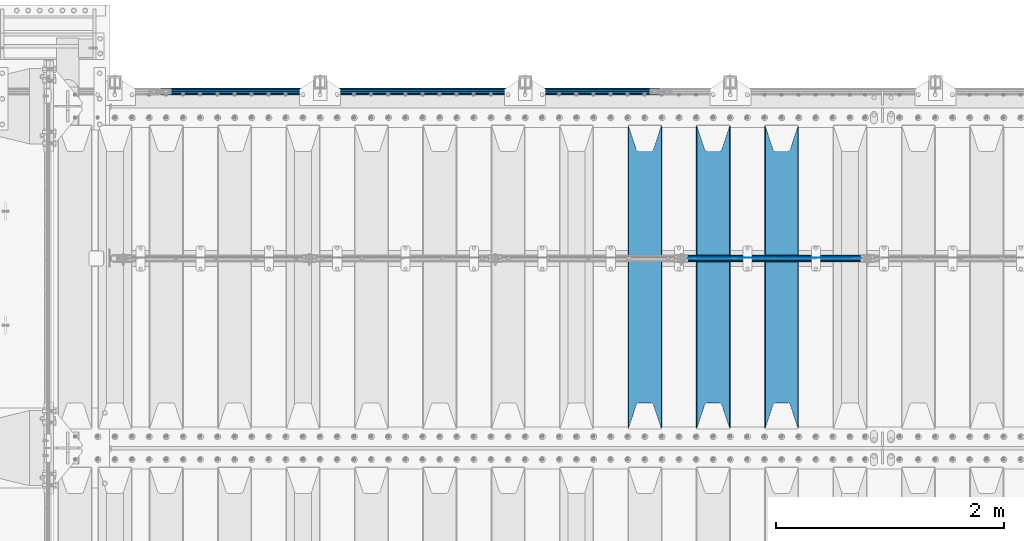
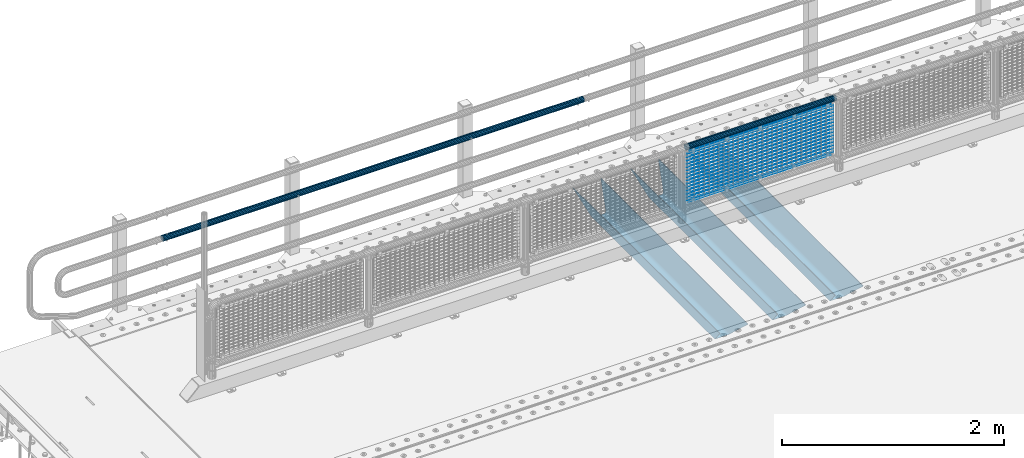
# One storey, part 131 of 270: 22 beams.
"""IFC2X3 building model written with IfcOpenShell, lengths in millimetres."""

from ifc_helpers import new_model, si_unit, frame, origin_with_axes, place, context, subcontext, project, spatial, faceted_brep, material, type_object, element, save


model = new_model("IFC2X3")

# Units and contexts
model_context = context("Model", 3, precision=1e-05, world=origin_with_axes())
body_context = subcontext(model_context, "Body", "Model", "MODEL_VIEW")
ifc_project = project(units=[si_unit("LENGTHUNIT", "METRE", prefix="MILLI"), si_unit("AREAUNIT", "SQUARE_METRE"), si_unit("VOLUMEUNIT", "CUBIC_METRE"), si_unit("MASSUNIT", "GRAM", prefix="KILO"), si_unit("TIMEUNIT", "SECOND"), si_unit("PLANEANGLEUNIT", "RADIAN"), si_unit("SOLIDANGLEUNIT", "STERADIAN"), si_unit("THERMODYNAMICTEMPERATUREUNIT", "DEGREE_CELSIUS"), si_unit("LUMINOUSINTENSITYUNIT", "LUMEN")], contexts=[model_context])

# Site, building, storey
site_placement = place(None, origin_with_axes())
site = spatial("IfcSite", under=ifc_project, at=site_placement, CompositionType="ELEMENT")
building_placement = place(site_placement, origin_with_axes())
building = spatial("IfcBuilding", under=site, at=building_placement, Name="Standard", CompositionType="ELEMENT")
storey_placement = place(building_placement, origin_with_axes())
storey = spatial("IfcBuildingStorey", under=building, at=storey_placement, Name="Undefined", CompositionType="ELEMENT", Elevation=0.0)

# Beams
ifc_material_1 = material()
beam_type_1 = type_object("IfcBeamType", PredefinedType="NOTDEFINED")
beam_1_placement = place(storey_placement, frame((5333.99999999987, -14870.1499999999, 689.849999999726), z_axis=(0.0, 0.0, -1.0), x_axis=(-1.0, 0.0, 0.0)))
element("IfcBeam", 1, at=beam_1_placement, inside=storey, type_object=beam_type_1, material=ifc_material_1, context=body_context, shape_type="Brep", body=[
    faceted_brep([(0.0, -26.5499999999993, 0.0), (0.0, -24.5290015881747, 10.1602451292931), (4384.00249699992, -24.5290015881747, 10.1602451292931), (4384.00249699992, -26.5499999999993, 0.0), (0.0, -18.7736850405036, 18.7736850405028), (4384.00249699992, -18.7736850405036, 18.7736850405028), (0.0, -10.1602451292929, 24.5290015881747), (4384.00249699992, -10.1602451292929, 24.5290015881747), (0.0, 0.0, 26.55), (4384.00249699992, 0.0, 26.55), (0.0, 10.1602451292929, 24.5290015881747), (4384.00249699992, 10.1602451292929, 24.5290015881747), (0.0, 18.7736850405036, 18.7736850405028), (4384.00249699992, 18.7736850405036, 18.7736850405028), (0.0, 24.5290015881747, 10.1602451292931), (4384.00249699992, 24.5290015881747, 10.1602451292931), (0.0, 26.5499999999993, 0.0), (4384.00249699992, 26.5499999999993, 0.0), (0.0, 24.5290015881747, -10.1602451292931), (4384.00249699992, 24.5290015881747, -10.1602451292931), (0.0, 18.7736850405036, -18.7736850405028), (4384.00249699992, 18.7736850405036, -18.7736850405028), (0.0, 10.1602451292929, -24.5290015881747), (4384.00249699992, 10.1602451292929, -24.5290015881747), (0.0, 0.0, -26.55), (4384.00249699992, 0.0, -26.55), (0.0, -10.1602451292929, -24.5290015881747), (4384.00249699992, -10.1602451292929, -24.5290015881747), (0.0, -18.7736850405036, -18.7736850405028), (4384.00249699992, -18.7736850405036, -18.7736850405028), (0.0, -24.5290015881747, -10.1602451292931), (4384.00249699992, -24.5290015881747, -10.1602451292931), (0.0, -30.1499999999996, 0.0), (0.0, -27.8549679052157, -11.5379054858058), (4384.00249699992, -27.8549679052157, -11.5379054858075), (4384.00249699992, -30.1499999999996, 0.0), (0.0, -21.3192694527752, -21.3192694527752), (4384.00249699992, -21.3192694527752, -21.3192694527744), (0.0, -11.5379054858076, -27.8549679052157), (4384.00249699992, -11.5379054858076, -27.8549679052153), (0.0, 0.0, -30.1500000000015), (4384.00249699992, 0.0, -30.15), (0.0, 11.5379054858076, -27.8549679052157), (4384.00249699992, 11.5379054858076, -27.8549679052153), (0.0, 21.3192694527752, -21.3192694527752), (4384.00249699992, 21.3192694527752, -21.3192694527744), (0.0, 27.8549679052157, -11.5379054858058), (4384.00249699992, 27.8549679052157, -11.5379054858074), (0.0, 30.1499999999996, 0.0), (4384.00249699992, 30.1499999999996, 0.0), (0.0, 27.8549679052157, 11.5379054858058), (4384.00249699992, 27.8549679052157, 11.5379054858075), (0.0, 21.3192694527752, 21.3192694527752), (4384.00249699992, 21.3192694527752, 21.3192694527744), (0.0, 11.5379054858076, 27.8549679052157), (4384.00249699992, 11.5379054858076, 27.8549679052153), (0.0, 0.0, 30.1500000000015), (4384.00249699992, 0.0, 30.15), (0.0, -11.5379054858076, 27.8549679052157), (4384.00249699992, -11.5379054858076, 27.8549679052153), (0.0, -21.3192694527752, 21.3192694527752), (4384.00249699992, -21.3192694527752, 21.3192694527744), (0.0, -27.8549679052157, 11.5379054858058), (4384.00249699992, -27.8549679052157, 11.5379054858075)], [[[0, 1, 2, 3]], [[1, 4, 5, 2]], [[4, 6, 7, 5]], [[6, 8, 9, 7]], [[8, 10, 11, 9]], [[10, 12, 13, 11]], [[12, 14, 15, 13]], [[14, 16, 17, 15]], [[16, 18, 19, 17]], [[18, 20, 21, 19]], [[20, 22, 23, 21]], [[22, 24, 25, 23]], [[24, 26, 27, 25]], [[26, 28, 29, 27]], [[28, 30, 31, 29]], [[30, 0, 3, 31]], [[32, 33, 34, 35]], [[33, 36, 37, 34]], [[36, 38, 39, 37]], [[38, 40, 41, 39]], [[40, 42, 43, 41]], [[42, 44, 45, 43]], [[44, 46, 47, 45]], [[46, 48, 49, 47]], [[48, 50, 51, 49]], [[50, 52, 53, 51]], [[52, 54, 55, 53]], [[54, 56, 57, 55]], [[56, 58, 59, 57]], [[58, 60, 61, 59]], [[60, 62, 63, 61]], [[62, 32, 35, 63]], [[37, 39, 41, 43, 45, 47, 49, 51, 53, 55, 57, 59, 61, 63, 35, 34], [5, 7, 9, 11, 13, 15, 17, 19, 21, 23, 25, 27, 29, 31, 3, 2]], [[62, 60, 58, 56, 54, 52, 50, 48, 46, 44, 42, 40, 38, 36, 33, 32], [30, 28, 26, 24, 22, 20, 18, 16, 14, 12, 10, 8, 6, 4, 1, 0]]]),
])
ifc_material_2 = material(Name="STEEL/S355N")
beam_type_2 = type_object("IfcBeamType", PredefinedType="NOTDEFINED")
beam_2_placement = place(storey_placement, frame((6400.0, -17825.0, -115.0), z_axis=(0.0, 0.0, 1.0), x_axis=(0.0, 1.0, 0.0)))
element("IfcBeam", 2, at=beam_2_placement, inside=storey, type_object=beam_type_2, material=ifc_material_2, context=body_context, shape_type="Brep", body=[
    faceted_brep([(0.0, 150.0, 115.0), (0.0, 143.689999999999, 115.0), (2650.00000000297, 143.689999999999, 115.0), (2650.00000000297, 150.0, 115.0), (2650.00000000297, 142.059565218398, 110.000000003096), (2650.00000000297, 148.3695652184, 110.000000003096), (2441.90079219209, -80.1103600731112, -98.0992078077845), (2437.7588105432, -77.5672621345584, -102.241189456673), (2434.06523489747, -74.4080125315522, -105.934765102404), (2430.9108609509, -70.710272125576, -109.089139048974), (2428.37322971128, -66.5649389910068, -111.626770288588), (2426.51472138055, -62.0739139532889, -113.485278619323), (2425.38102192092, -57.3475956567672, -114.618978078955), (2424.99999999987, -52.5021667386536, -115.0), (2424.99999999987, 52.5021667386536, -115.0), (2425.38102192092, 57.3475956567672, -114.618978078955), (2426.51472138055, 62.0739139532889, -113.485278619323), (2428.37322971128, 66.5649389910068, -111.626770288588), (2430.9108609509, 70.710272125576, -109.089139048974), (2434.06523489747, 74.4080125315522, -105.934765102404), (2437.7588105432, 77.5672621345584, -102.241189456673), (2441.90079219209, 80.1103600731112, -98.0992078077846), (2446.38936140511, 81.9747917625791, -93.6106385947584), (2448.2494850041, 76.2713538057251, -91.7505149957729), (2444.62967112263, 74.76777986261, -95.3703288772456), (2441.28936334126, 72.7168944282894, -98.710636658607), (2438.31067330439, 70.1691124903846, -101.689326695487), (2435.76682334747, 67.1870637758839, -104.233176652398), (2433.72034654133, 63.8440531834895, -106.279653458539), (2432.22154950042, 60.222258798236, -107.778450499454), (2431.30727574265, 56.4107117849089, -108.692724257221), (2430.99999999987, 52.5031078186876, -109.0), (2430.99999999987, -52.5031078186876, -109.0), (2431.30727574265, -56.4107117849089, -108.692724257221), (2432.22154950042, -60.222258798236, -107.778450499454), (2433.72034654133, -63.8440531834895, -106.279653458539), (2435.76682334747, -67.1870637758839, -104.233176652398), (2438.31067330438, -70.1691124903846, -101.689326695487), (2441.28936334126, -72.7168944282894, -98.7106366586071), (2444.62967112263, -74.76777986261, -95.3703288772457), (2448.2494850041, -76.2713538057251, -91.7505149957729), (2650.00000000297, -142.059565218398, 110.000000003096), (2650.00000000297, -148.3695652184, 110.000000003096), (2446.38936140511, -81.9747917625791, -93.6106385947584), (2650.00000000297, -143.689999999999, 115.0), (2650.00000000297, -150.0, 115.0), (0.0, -143.689999999999, 115.0), (0.0, -150.0, 115.0), (0.0, -148.369565218261, 110.000000002672), (203.610638597431, -81.9747917625791, -93.6106385947584), (208.099207810457, -80.1103600731112, -98.0992078077845), (212.241189459342, -77.5672621345584, -102.241189456673), (215.934765105078, -74.4080125315522, -105.934765102404), (219.089139051644, -70.710272125576, -109.089139048974), (221.626770291259, -66.5649389910068, -111.626770288588), (223.485278621993, -62.0739139532889, -113.485278619323), (224.618978081628, -57.3475956567672, -114.618978078955), (225.00000000267, -52.5021667386536, -115.0), (225.00000000267, 52.5021667386536, -115.0), (224.618978081628, 57.3475956567672, -114.618978078955), (223.485278621993, 62.0739139532889, -113.485278619323), (221.626770291259, 66.5649389910068, -111.626770288588), (219.089139051644, 70.710272125576, -109.089139048974), (215.934765105078, 74.4080125315522, -105.934765102404), (212.241189459342, 77.5672621345584, -102.241189456673), (208.099207810457, 80.1103600731112, -98.0992078077846), (203.610638597431, 81.9747917625791, -93.6106385947584), (0.0, 148.369565218261, 110.000000002672), (0.0, 142.05956521826, 110.000000002672), (201.750514998446, 76.2713538057251, -91.7505149957729), (205.370328879915, 74.76777986261, -95.3703288772456), (208.710636661279, 72.7168944282894, -98.710636658607), (211.689326698157, 70.1691124903846, -101.689326695487), (214.233176655071, 67.1870637758839, -104.233176652398), (216.27965346121, 63.8440531834895, -106.279653458539), (217.778450502126, 60.222258798236, -107.778450499454), (218.692724259894, 56.4107117849089, -108.692724257221), (219.00000000267, 52.5031078186876, -109.0), (219.00000000267, -52.5031078186876, -109.0), (218.692724259894, -56.4107117849089, -108.692724257221), (217.778450502123, -60.222258798236, -107.778450499454), (216.27965346121, -63.8440531834895, -106.279653458539), (214.233176655071, -67.1870637758839, -104.233176652398), (211.689326698157, -70.1691124903846, -101.689326695487), (208.710636661279, -72.7168944282894, -98.7106366586071), (205.370328879915, -74.76777986261, -95.3703288772457), (201.750514998446, -76.2713538057251, -91.7505149957729), (0.0, -142.05956521826, 110.000000002672)], [[[0, 1, 2, 3]], [[3, 2, 4, 5]], [[6, 7, 8, 9, 10, 11, 12, 13, 14, 15, 16, 17, 18, 19, 20, 21, 22, 5, 4, 23, 24, 25, 26, 27, 28, 29, 30, 31, 32, 33, 34, 35, 36, 37, 38, 39, 40, 41, 42, 43]], [[44, 45, 42, 41]], [[46, 47, 45, 44]], [[43, 42, 45, 47, 48, 49]], [[6, 43, 49, 50]], [[7, 6, 50, 51]], [[8, 7, 51, 52]], [[9, 8, 52, 53]], [[10, 9, 53, 54]], [[11, 10, 54, 55]], [[12, 11, 55, 56]], [[13, 12, 56, 57]], [[14, 13, 57, 58]], [[15, 14, 58, 59]], [[16, 15, 59, 60]], [[17, 16, 60, 61]], [[18, 17, 61, 62]], [[19, 18, 62, 63]], [[20, 19, 63, 64]], [[21, 20, 64, 65]], [[22, 21, 65, 66]], [[0, 3, 5, 22, 66, 67]], [[1, 0, 67, 68]], [[23, 4, 2, 1, 68, 69]], [[24, 23, 69, 70]], [[25, 24, 70, 71]], [[26, 25, 71, 72]], [[27, 26, 72, 73]], [[28, 27, 73, 74]], [[29, 28, 74, 75]], [[30, 29, 75, 76]], [[31, 30, 76, 77]], [[32, 31, 77, 78]], [[33, 32, 78, 79]], [[34, 33, 79, 80]], [[35, 34, 80, 81]], [[36, 35, 81, 82]], [[37, 36, 82, 83]], [[38, 37, 83, 84]], [[39, 38, 84, 85]], [[40, 39, 85, 86]], [[46, 44, 41, 40, 86, 87]], [[47, 46, 87, 48]], [[86, 85, 84, 83, 82, 81, 80, 79, 78, 77, 76, 75, 74, 73, 72, 71, 70, 69, 68, 67, 66, 65, 64, 63, 62, 61, 60, 59, 58, 57, 56, 55, 54, 53, 52, 51, 50, 49, 48, 87]]]),
])
beam_3_placement = place(storey_placement, frame((5800.0, -17825.0, -115.0), z_axis=(0.0, 0.0, 1.0), x_axis=(0.0, 1.0, 0.0)))
element("IfcBeam", 3, at=beam_3_placement, inside=storey, type_object=beam_type_2, material=ifc_material_2, context=body_context, shape_type="Brep", body=[
    faceted_brep([(0.0, 150.0, 115.0), (0.0, 143.689999999999, 115.0), (2650.00000000297, 143.689999999999, 115.0), (2650.00000000297, 150.0, 115.0), (2650.00000000297, 142.059565218398, 110.000000003096), (2650.00000000297, 148.3695652184, 110.000000003096), (2441.90079219209, -80.1103600731112, -98.0992078077845), (2437.7588105432, -77.5672621345584, -102.241189456673), (2434.06523489747, -74.4080125315522, -105.934765102404), (2430.9108609509, -70.710272125576, -109.089139048974), (2428.37322971128, -66.5649389910068, -111.626770288588), (2426.51472138055, -62.0739139532889, -113.485278619323), (2425.38102192092, -57.3475956567672, -114.618978078955), (2424.99999999987, -52.5021667386536, -115.0), (2424.99999999987, 52.5021667386536, -115.0), (2425.38102192092, 57.3475956567672, -114.618978078955), (2426.51472138055, 62.0739139532889, -113.485278619323), (2428.37322971128, 66.5649389910068, -111.626770288588), (2430.9108609509, 70.710272125576, -109.089139048974), (2434.06523489747, 74.4080125315522, -105.934765102404), (2437.7588105432, 77.5672621345584, -102.241189456673), (2441.90079219209, 80.1103600731112, -98.0992078077846), (2446.38936140511, 81.9747917625791, -93.6106385947584), (2448.2494850041, 76.2713538057251, -91.7505149957729), (2444.62967112263, 74.76777986261, -95.3703288772456), (2441.28936334126, 72.7168944282894, -98.710636658607), (2438.31067330439, 70.1691124903846, -101.689326695487), (2435.76682334747, 67.1870637758839, -104.233176652398), (2433.72034654133, 63.8440531834895, -106.279653458539), (2432.22154950042, 60.222258798236, -107.778450499454), (2431.30727574265, 56.4107117849089, -108.692724257221), (2430.99999999987, 52.5031078186876, -109.0), (2430.99999999987, -52.5031078186876, -109.0), (2431.30727574265, -56.4107117849089, -108.692724257221), (2432.22154950042, -60.222258798236, -107.778450499454), (2433.72034654133, -63.8440531834895, -106.279653458539), (2435.76682334747, -67.1870637758839, -104.233176652398), (2438.31067330438, -70.1691124903846, -101.689326695487), (2441.28936334126, -72.7168944282894, -98.7106366586071), (2444.62967112263, -74.76777986261, -95.3703288772457), (2448.2494850041, -76.2713538057251, -91.7505149957729), (2650.00000000297, -142.059565218398, 110.000000003096), (2650.00000000297, -148.3695652184, 110.000000003096), (2446.38936140511, -81.9747917625791, -93.6106385947584), (2650.00000000297, -143.689999999999, 115.0), (2650.00000000297, -150.0, 115.0), (0.0, -143.689999999999, 115.0), (0.0, -150.0, 115.0), (0.0, -148.369565218261, 110.000000002672), (203.610638597431, -81.9747917625791, -93.6106385947584), (208.099207810457, -80.1103600731112, -98.0992078077845), (212.241189459342, -77.5672621345584, -102.241189456673), (215.934765105078, -74.4080125315522, -105.934765102404), (219.089139051644, -70.710272125576, -109.089139048974), (221.626770291259, -66.5649389910068, -111.626770288588), (223.485278621993, -62.0739139532889, -113.485278619323), (224.618978081628, -57.3475956567672, -114.618978078955), (225.00000000267, -52.5021667386536, -115.0), (225.00000000267, 52.5021667386536, -115.0), (224.618978081628, 57.3475956567672, -114.618978078955), (223.485278621993, 62.0739139532889, -113.485278619323), (221.626770291259, 66.5649389910068, -111.626770288588), (219.089139051644, 70.710272125576, -109.089139048974), (215.934765105078, 74.4080125315522, -105.934765102404), (212.241189459342, 77.5672621345584, -102.241189456673), (208.099207810457, 80.1103600731112, -98.0992078077846), (203.610638597431, 81.9747917625791, -93.6106385947584), (0.0, 148.369565218261, 110.000000002672), (0.0, 142.05956521826, 110.000000002672), (201.750514998446, 76.2713538057251, -91.7505149957729), (205.370328879915, 74.76777986261, -95.3703288772456), (208.710636661279, 72.7168944282894, -98.710636658607), (211.689326698157, 70.1691124903846, -101.689326695487), (214.233176655071, 67.1870637758839, -104.233176652398), (216.27965346121, 63.8440531834895, -106.279653458539), (217.778450502126, 60.222258798236, -107.778450499454), (218.692724259894, 56.4107117849089, -108.692724257221), (219.00000000267, 52.5031078186876, -109.0), (219.00000000267, -52.5031078186876, -109.0), (218.692724259894, -56.4107117849089, -108.692724257221), (217.778450502123, -60.222258798236, -107.778450499454), (216.27965346121, -63.8440531834895, -106.279653458539), (214.233176655071, -67.1870637758839, -104.233176652398), (211.689326698157, -70.1691124903846, -101.689326695487), (208.710636661279, -72.7168944282894, -98.7106366586071), (205.370328879915, -74.76777986261, -95.3703288772457), (201.750514998446, -76.2713538057251, -91.7505149957729), (0.0, -142.05956521826, 110.000000002672)], [[[0, 1, 2, 3]], [[3, 2, 4, 5]], [[6, 7, 8, 9, 10, 11, 12, 13, 14, 15, 16, 17, 18, 19, 20, 21, 22, 5, 4, 23, 24, 25, 26, 27, 28, 29, 30, 31, 32, 33, 34, 35, 36, 37, 38, 39, 40, 41, 42, 43]], [[44, 45, 42, 41]], [[46, 47, 45, 44]], [[43, 42, 45, 47, 48, 49]], [[6, 43, 49, 50]], [[7, 6, 50, 51]], [[8, 7, 51, 52]], [[9, 8, 52, 53]], [[10, 9, 53, 54]], [[11, 10, 54, 55]], [[12, 11, 55, 56]], [[13, 12, 56, 57]], [[14, 13, 57, 58]], [[15, 14, 58, 59]], [[16, 15, 59, 60]], [[17, 16, 60, 61]], [[18, 17, 61, 62]], [[19, 18, 62, 63]], [[20, 19, 63, 64]], [[21, 20, 64, 65]], [[22, 21, 65, 66]], [[0, 3, 5, 22, 66, 67]], [[1, 0, 67, 68]], [[23, 4, 2, 1, 68, 69]], [[24, 23, 69, 70]], [[25, 24, 70, 71]], [[26, 25, 71, 72]], [[27, 26, 72, 73]], [[28, 27, 73, 74]], [[29, 28, 74, 75]], [[30, 29, 75, 76]], [[31, 30, 76, 77]], [[32, 31, 77, 78]], [[33, 32, 78, 79]], [[34, 33, 79, 80]], [[35, 34, 80, 81]], [[36, 35, 81, 82]], [[37, 36, 82, 83]], [[38, 37, 83, 84]], [[39, 38, 84, 85]], [[40, 39, 85, 86]], [[46, 44, 41, 40, 86, 87]], [[47, 46, 87, 48]], [[86, 85, 84, 83, 82, 81, 80, 79, 78, 77, 76, 75, 74, 73, 72, 71, 70, 69, 68, 67, 66, 65, 64, 63, 62, 61, 60, 59, 58, 57, 56, 55, 54, 53, 52, 51, 50, 49, 48, 87]]]),
])
beam_4_placement = place(storey_placement, frame((5200.0, -17825.0, -115.0), z_axis=(0.0, 0.0, 1.0), x_axis=(0.0, 1.0, 0.0)))
element("IfcBeam", 4, at=beam_4_placement, inside=storey, type_object=beam_type_2, material=ifc_material_2, context=body_context, shape_type="Brep", body=[
    faceted_brep([(0.0, 150.0, 115.0), (0.0, 143.689999999999, 115.0), (2650.00000000297, 143.689999999999, 115.0), (2650.00000000297, 150.0, 115.0), (2650.00000000297, 142.059565218398, 110.000000003096), (2650.00000000297, 148.3695652184, 110.000000003096), (2441.90079219209, -80.1103600731112, -98.0992078077845), (2437.7588105432, -77.5672621345584, -102.241189456673), (2434.06523489747, -74.4080125315522, -105.934765102404), (2430.9108609509, -70.710272125576, -109.089139048974), (2428.37322971128, -66.5649389910068, -111.626770288588), (2426.51472138055, -62.0739139532889, -113.485278619323), (2425.38102192092, -57.3475956567672, -114.618978078955), (2424.99999999987, -52.5021667386536, -115.0), (2424.99999999987, 52.5021667386536, -115.0), (2425.38102192092, 57.3475956567672, -114.618978078955), (2426.51472138055, 62.0739139532889, -113.485278619323), (2428.37322971128, 66.5649389910068, -111.626770288588), (2430.9108609509, 70.710272125576, -109.089139048974), (2434.06523489747, 74.4080125315522, -105.934765102404), (2437.7588105432, 77.5672621345584, -102.241189456673), (2441.90079219209, 80.1103600731112, -98.0992078077846), (2446.38936140511, 81.9747917625791, -93.6106385947584), (2448.2494850041, 76.2713538057251, -91.7505149957729), (2444.62967112263, 74.76777986261, -95.3703288772456), (2441.28936334126, 72.7168944282894, -98.710636658607), (2438.31067330439, 70.1691124903846, -101.689326695487), (2435.76682334747, 67.1870637758839, -104.233176652398), (2433.72034654133, 63.8440531834895, -106.279653458539), (2432.22154950042, 60.222258798236, -107.778450499454), (2431.30727574265, 56.4107117849089, -108.692724257221), (2430.99999999987, 52.5031078186876, -109.0), (2430.99999999987, -52.5031078186876, -109.0), (2431.30727574265, -56.4107117849089, -108.692724257221), (2432.22154950042, -60.222258798236, -107.778450499454), (2433.72034654133, -63.8440531834895, -106.279653458539), (2435.76682334747, -67.1870637758839, -104.233176652398), (2438.31067330438, -70.1691124903846, -101.689326695487), (2441.28936334126, -72.7168944282894, -98.7106366586071), (2444.62967112263, -74.76777986261, -95.3703288772457), (2448.2494850041, -76.2713538057251, -91.7505149957729), (2650.00000000297, -142.059565218398, 110.000000003096), (2650.00000000297, -148.3695652184, 110.000000003096), (2446.38936140511, -81.9747917625791, -93.6106385947584), (2650.00000000297, -143.689999999999, 115.0), (2650.00000000297, -150.0, 115.0), (0.0, -143.689999999999, 115.0), (0.0, -150.0, 115.0), (0.0, -148.369565218261, 110.000000002672), (203.610638597431, -81.9747917625791, -93.6106385947584), (208.099207810457, -80.1103600731112, -98.0992078077845), (212.241189459342, -77.5672621345584, -102.241189456673), (215.934765105078, -74.4080125315522, -105.934765102404), (219.089139051644, -70.710272125576, -109.089139048974), (221.626770291259, -66.5649389910068, -111.626770288588), (223.485278621993, -62.0739139532889, -113.485278619323), (224.618978081628, -57.3475956567672, -114.618978078955), (225.00000000267, -52.5021667386536, -115.0), (225.00000000267, 52.5021667386536, -115.0), (224.618978081628, 57.3475956567672, -114.618978078955), (223.485278621993, 62.0739139532889, -113.485278619323), (221.626770291259, 66.5649389910068, -111.626770288588), (219.089139051644, 70.710272125576, -109.089139048974), (215.934765105078, 74.4080125315522, -105.934765102404), (212.241189459342, 77.5672621345584, -102.241189456673), (208.099207810457, 80.1103600731112, -98.0992078077846), (203.610638597431, 81.9747917625791, -93.6106385947584), (0.0, 148.369565218261, 110.000000002672), (0.0, 142.05956521826, 110.000000002672), (201.750514998446, 76.2713538057251, -91.7505149957729), (205.370328879915, 74.76777986261, -95.3703288772456), (208.710636661279, 72.7168944282894, -98.710636658607), (211.689326698157, 70.1691124903846, -101.689326695487), (214.233176655071, 67.1870637758839, -104.233176652398), (216.27965346121, 63.8440531834895, -106.279653458539), (217.778450502126, 60.222258798236, -107.778450499454), (218.692724259894, 56.4107117849089, -108.692724257221), (219.00000000267, 52.5031078186876, -109.0), (219.00000000267, -52.5031078186876, -109.0), (218.692724259894, -56.4107117849089, -108.692724257221), (217.778450502123, -60.222258798236, -107.778450499454), (216.27965346121, -63.8440531834895, -106.279653458539), (214.233176655071, -67.1870637758839, -104.233176652398), (211.689326698157, -70.1691124903846, -101.689326695487), (208.710636661279, -72.7168944282894, -98.7106366586071), (205.370328879915, -74.76777986261, -95.3703288772457), (201.750514998446, -76.2713538057251, -91.7505149957729), (0.0, -142.05956521826, 110.000000002672)], [[[0, 1, 2, 3]], [[3, 2, 4, 5]], [[6, 7, 8, 9, 10, 11, 12, 13, 14, 15, 16, 17, 18, 19, 20, 21, 22, 5, 4, 23, 24, 25, 26, 27, 28, 29, 30, 31, 32, 33, 34, 35, 36, 37, 38, 39, 40, 41, 42, 43]], [[44, 45, 42, 41]], [[46, 47, 45, 44]], [[43, 42, 45, 47, 48, 49]], [[6, 43, 49, 50]], [[7, 6, 50, 51]], [[8, 7, 51, 52]], [[9, 8, 52, 53]], [[10, 9, 53, 54]], [[11, 10, 54, 55]], [[12, 11, 55, 56]], [[13, 12, 56, 57]], [[14, 13, 57, 58]], [[15, 14, 58, 59]], [[16, 15, 59, 60]], [[17, 16, 60, 61]], [[18, 17, 61, 62]], [[19, 18, 62, 63]], [[20, 19, 63, 64]], [[21, 20, 64, 65]], [[22, 21, 65, 66]], [[0, 3, 5, 22, 66, 67]], [[1, 0, 67, 68]], [[23, 4, 2, 1, 68, 69]], [[24, 23, 69, 70]], [[25, 24, 70, 71]], [[26, 25, 71, 72]], [[27, 26, 72, 73]], [[28, 27, 73, 74]], [[29, 28, 74, 75]], [[30, 29, 75, 76]], [[31, 30, 76, 77]], [[32, 31, 77, 78]], [[33, 32, 78, 79]], [[34, 33, 79, 80]], [[35, 34, 80, 81]], [[36, 35, 81, 82]], [[37, 36, 82, 83]], [[38, 37, 83, 84]], [[39, 38, 84, 85]], [[40, 39, 85, 86]], [[46, 44, 41, 40, 86, 87]], [[47, 46, 87, 48]], [[86, 85, 84, 83, 82, 81, 80, 79, 78, 77, 76, 75, 74, 73, 72, 71, 70, 69, 68, 67, 66, 65, 64, 63, 62, 61, 60, 59, 58, 57, 56, 55, 54, 53, 52, 51, 50, 49, 48, 87]]]),
])
ifc_material_3 = material(Name="Misc_Undefined")
beam_type_3 = type_object("IfcBeamType", Name="D3", PredefinedType="NOTDEFINED")
for number, where, z_axis, x_axis in (
    (5, (5575.0, -16329.5, 851.596999999999), (0.0, 0.0, 1.0), (1.0, 0.0, 0.0)),
    (6, (5575.0, -16329.5, 669.452), (0.0, 0.0, 1.0), (1.0, 0.0, 0.0)),
    (7, (5575.0, -16329.5, 523.736), (0.0, 0.0, 1.0), (1.0, 0.0, 0.0)),
    (8, (5575.0, -16329.5, 487.307), (0.0, 0.0, 1.0), (1.0, 0.0, 0.0)),
    (9, (5575.0, -16329.5, 705.881), (0.0, 0.0, 1.0), (1.0, 0.0, 0.0)),
    (10, (5575.0, -16329.5, 596.594), (0.0, 0.0, 1.0), (1.0, 0.0, 0.0)),
    (11, (5575.0, -16329.5, 450.878), (0.0, 0.0, 1.0), (1.0, 0.0, 0.0)),
    (12, (5575.0, -16329.5, 815.167999999999), (0.0, 0.0, 1.0), (1.0, 0.0, 0.0)),
    (13, (5575.0, -16329.5, 888.025999999999), (0.0, 0.0, 1.0), (1.0, 0.0, 0.0)),
    (14, (5575.0, -16329.5, 778.738999999999), (0.0, 0.0, 1.0), (1.0, 0.0, 0.0)),
    (15, (5575.0, -16329.5, 742.309999999999), (0.0, 0.0, 1.0), (1.0, 0.0, 0.0)),
    (16, (5575.0, -16329.5, 633.023), (0.0, 0.0, 1.0), (1.0, 0.0, 0.0)),
    (17, (5575.0, -16329.5, 560.165), (0.0, 0.0, 1.0), (1.0, 0.0, 0.0)),
    (18, (5575.0, -16329.5, 414.449), (0.0, 0.0, 1.0), (1.0, 0.0, 0.0)),
):
    element("IfcBeam", number, at=place(storey_placement, frame(where, z_axis=z_axis, x_axis=x_axis)), inside=storey, type_object=beam_type_3, material=ifc_material_3, ObjectType="D3", context=body_context, shape_type="Brep", body=[
        faceted_brep([(0.0, -1.5, 0.0), (0.0, -0.75, -1.29903810567669), (1523.0, -0.75, -1.29903810567669), (1523.0, -1.5, 0.0), (0.0, 0.75, -1.29903810567669), (1523.0, 0.75, -1.29903810567669), (0.0, 1.5, 0.0), (1523.0, 1.5, 0.0), (0.0, 0.75, 1.29903810567669), (1523.0, 0.75, 1.29903810567669), (0.0, -0.75, 1.29903810567669), (1523.0, -0.75, 1.29903810567669)], [[[0, 1, 2, 3]], [[1, 4, 5, 2]], [[4, 6, 7, 5]], [[6, 8, 9, 7]], [[8, 10, 11, 9]], [[10, 0, 3, 11]], [[5, 7, 9, 11, 3, 2]], [[10, 8, 6, 4, 1, 0]]]),
    ])
beam_5_placement = place(storey_placement, frame((5600.0, -16329.5, 353.02), z_axis=(0.0, 0.0, 1.0), x_axis=(1.0, 0.0, 0.0)))
element("IfcBeam", 19, at=beam_5_placement, inside=storey, type_object=beam_type_3, material=ifc_material_3, ObjectType="D3", context=body_context, shape_type="Brep", body=[
    faceted_brep([(0.0, -1.5, 0.0), (0.0, -0.75, -1.29903810567669), (1473.0, -0.75, -1.29903810567669), (1473.0, -1.5, 0.0), (0.0, 0.75, -1.29903810567669), (1473.0, 0.75, -1.29903810567663), (0.0, 1.5, 0.0), (1473.0, 1.5, 0.0), (0.0, 0.75, 1.29903810567669), (1473.0, 0.75, 1.29903810567669), (0.0, -0.75, 1.29903810567669), (1473.0, -0.75, 1.29903810567669)], [[[0, 1, 2, 3]], [[1, 4, 5, 2]], [[4, 6, 7, 5]], [[6, 8, 9, 7]], [[8, 10, 11, 9]], [[10, 0, 3, 11]], [[5, 7, 9, 11, 3, 2]], [[10, 8, 6, 4, 1, 0]]]),
])
beam_6_placement = place(storey_placement, frame((5575.0, -16329.5, 378.02), z_axis=(0.0, 0.0, 1.0), x_axis=(1.0, 0.0, 0.0)))
element("IfcBeam", 20, at=beam_6_placement, inside=storey, type_object=beam_type_3, material=ifc_material_3, ObjectType="D3", context=body_context, shape_type="Brep", body=[
    faceted_brep([(0.0, -1.5, 0.0), (0.0, -0.75, -1.29903810567669), (1523.0, -0.75, -1.29903810567669), (1523.0, -1.5, 0.0), (0.0, 0.75, -1.29903810567669), (1523.0, 0.75, -1.29903810567669), (0.0, 1.5, 0.0), (1523.0, 1.5, 0.0), (0.0, 0.75, 1.29903810567669), (1523.0, 0.75, 1.29903810567669), (0.0, -0.75, 1.29903810567669), (1523.0, -0.75, 1.29903810567669)], [[[0, 1, 2, 3]], [[1, 4, 5, 2]], [[4, 6, 7, 5]], [[6, 8, 9, 7]], [[8, 10, 11, 9]], [[10, 0, 3, 11]], [[5, 7, 9, 11, 3, 2]], [[10, 8, 6, 4, 1, 0]]]),
])
beam_7_placement = place(storey_placement, frame((5600.0, -16329.5, 913.02), z_axis=(0.0, 0.0, 1.0), x_axis=(1.0, 0.0, 0.0)))
element("IfcBeam", 21, at=beam_7_placement, inside=storey, type_object=beam_type_3, material=ifc_material_3, ObjectType="D3", context=body_context, shape_type="Brep", body=[
    faceted_brep([(0.0, -1.5, 0.0), (0.0, -0.75, -1.29903810567669), (1473.0, -0.75, -1.29903810567669), (1473.0, -1.5, 0.0), (0.0, 0.75, -1.29903810567669), (1473.0, 0.75, -1.29903810567663), (0.0, 1.5, 0.0), (1473.0, 1.5, 0.0), (0.0, 0.75, 1.29903810567669), (1473.0, 0.75, 1.29903810567669), (0.0, -0.75, 1.29903810567669), (1473.0, -0.75, 1.29903810567669)], [[[0, 1, 2, 3]], [[1, 4, 5, 2]], [[4, 6, 7, 5]], [[6, 8, 9, 7]], [[8, 10, 11, 9]], [[10, 0, 3, 11]], [[5, 7, 9, 11, 3, 2]], [[10, 8, 6, 4, 1, 0]]]),
])
beam_type_4 = type_object("IfcBeamType", PredefinedType="NOTDEFINED")
beam_8_placement = place(storey_placement, frame((5554.85, -16335.5, 969.849999999999), z_axis=(0.0, 0.0, 1.0), x_axis=(1.0, 0.0, 0.0)))
element("IfcBeam", 22, at=beam_8_placement, inside=storey, type_object=beam_type_4, material=ifc_material_1, context=body_context, shape_type="Brep", body=[
    faceted_brep([(0.0, -25.3500000000004, 0.0), (0.0, -23.4203461491616, 9.70102501045403), (1563.0, -23.4203461491616, 9.70102501045506), (1563.0, -25.3500000000004, 0.0), (0.0, -17.9251569030785, 17.9251569030785), (1563.0, -17.9251569030785, 17.925156903079), (0.0, -9.70102501045585, 23.4203461491597), (1563.0, -9.70102501045585, 23.4203461491611), (0.0, 0.0, 25.3499999999985), (1563.0, 0.0, 25.35), (0.0, 9.70102501045585, 23.4203461491597), (1563.0, 9.70102501045585, 23.4203461491611), (0.0, 17.9251569030785, 17.9251569030785), (1563.0, 17.9251569030785, 17.925156903079), (0.0, 23.4203461491616, 9.70102501045403), (1563.0, 23.4203461491616, 9.70102501045506), (0.0, 25.3500000000004, 0.0), (1563.0, 25.3500000000004, 0.0), (0.0, 23.4203461491616, -9.70102501045403), (1563.0, 23.4203461491616, -9.70102501045506), (0.0, 17.9251569030785, -17.9251569030785), (1563.0, 17.9251569030785, -17.925156903079), (0.0, 9.70102501045585, -23.4203461491597), (1563.0, 9.70102501045585, -23.4203461491611), (0.0, 0.0, -25.3499999999985), (1563.0, 0.0, -25.35), (0.0, -9.70102501045585, -23.4203461491597), (1563.0, -9.70102501045585, -23.4203461491611), (0.0, -17.9251569030785, -17.9251569030785), (1563.0, -17.9251569030785, -17.925156903079), (0.0, -23.4203461491616, -9.70102501045403), (1563.0, -23.4203461491616, -9.70102501045506), (0.0, -30.1499999999996, 0.0), (0.0, -27.8549679052157, -11.5379054858058), (1563.0, -27.8549679052157, -11.5379054858075), (1563.0, -30.1499999999996, 0.0), (0.0, -21.3192694527752, -21.3192694527752), (1563.0, -21.3192694527752, -21.3192694527744), (0.0, -11.5379054858076, -27.8549679052157), (1563.0, -11.5379054858076, -27.8549679052153), (0.0, 0.0, -30.1500000000015), (1563.0, 0.0, -30.15), (0.0, 11.5379054858076, -27.8549679052157), (1563.0, 11.5379054858076, -27.8549679052153), (0.0, 21.3192694527752, -21.3192694527752), (1563.0, 21.3192694527752, -21.3192694527744), (0.0, 27.8549679052157, -11.5379054858058), (1563.0, 27.8549679052157, -11.5379054858074), (0.0, 30.1499999999996, 0.0), (1563.0, 30.1499999999996, 0.0), (0.0, 27.8549679052157, 11.5379054858058), (1563.0, 27.8549679052157, 11.5379054858074), (0.0, 21.3192694527752, 21.3192694527752), (1563.0, 21.3192694527752, 21.3192694527744), (0.0, 11.5379054858076, 27.8549679052157), (1563.0, 11.5379054858076, 27.8549679052153), (0.0, 0.0, 30.1500000000015), (1563.0, 0.0, 30.15), (0.0, -11.5379054858076, 27.8549679052157), (1563.0, -11.5379054858076, 27.8549679052153), (0.0, -21.3192694527752, 21.3192694527752), (1563.0, -21.3192694527752, 21.3192694527744), (0.0, -27.8549679052157, 11.5379054858058), (1563.0, -27.8549679052157, 11.5379054858074)], [[[0, 1, 2, 3]], [[1, 4, 5, 2]], [[4, 6, 7, 5]], [[6, 8, 9, 7]], [[8, 10, 11, 9]], [[10, 12, 13, 11]], [[12, 14, 15, 13]], [[14, 16, 17, 15]], [[16, 18, 19, 17]], [[18, 20, 21, 19]], [[20, 22, 23, 21]], [[22, 24, 25, 23]], [[24, 26, 27, 25]], [[26, 28, 29, 27]], [[28, 30, 31, 29]], [[30, 0, 3, 31]], [[32, 33, 34, 35]], [[33, 36, 37, 34]], [[36, 38, 39, 37]], [[38, 40, 41, 39]], [[40, 42, 43, 41]], [[42, 44, 45, 43]], [[44, 46, 47, 45]], [[46, 48, 49, 47]], [[48, 50, 51, 49]], [[50, 52, 53, 51]], [[52, 54, 55, 53]], [[54, 56, 57, 55]], [[56, 58, 59, 57]], [[58, 60, 61, 59]], [[60, 62, 63, 61]], [[62, 32, 35, 63]], [[37, 39, 41, 43, 45, 47, 49, 51, 53, 55, 57, 59, 61, 63, 35, 34], [5, 7, 9, 11, 13, 15, 17, 19, 21, 23, 25, 27, 29, 31, 3, 2]], [[62, 60, 58, 56, 54, 52, 50, 48, 46, 44, 42, 40, 38, 36, 33, 32], [30, 28, 26, 24, 22, 20, 18, 16, 14, 12, 10, 8, 6, 4, 1, 0]]]),
])

save(model, "model.ifc")
